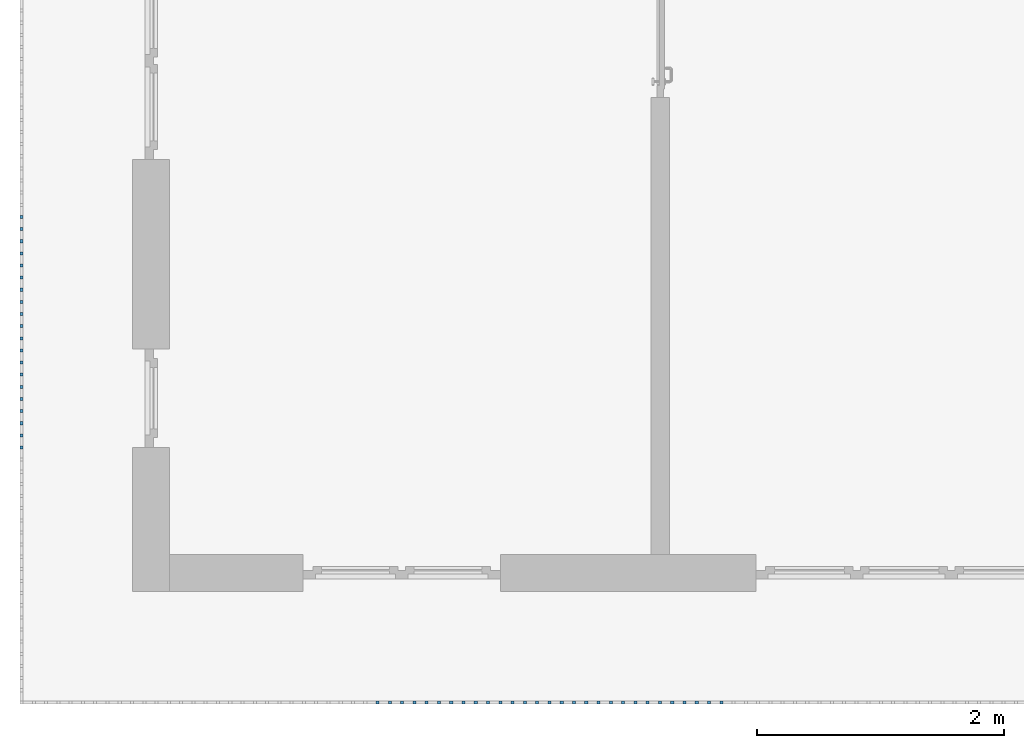
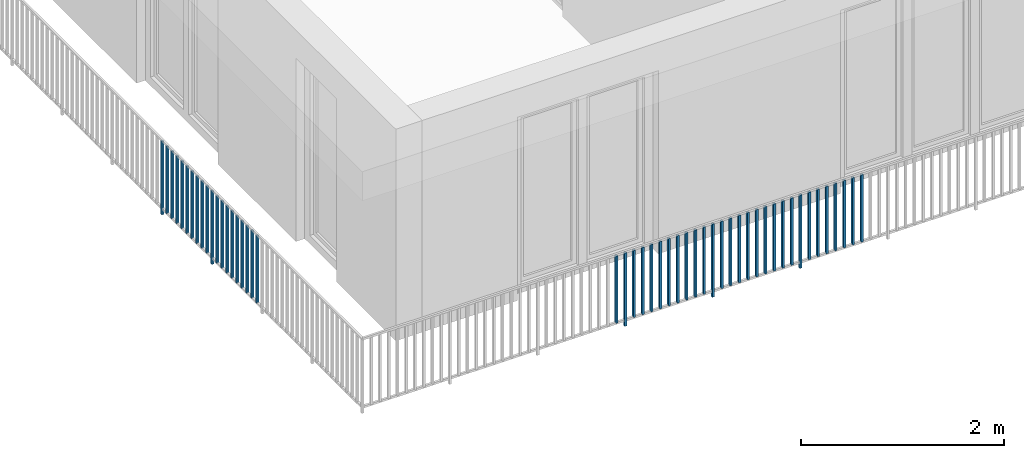
# One storey, part 33 of 54: 49 building element parts, 1 element without a shape of its own.
"""IFC4 building model written with IfcOpenShell, lengths in metres."""

from ifc_helpers import new_model, entity, si_unit, converted_unit, derived_unit, direction, frame, origin_with_axes, place, context, subcontext, project, spatial, polygons, material, type_object, element, aggregate, save


model = new_model("IFC4")

# Units and contexts
model_context = context("Model", 3, precision=1e-05, world=origin_with_axes(), true_north=direction((0.0, 1.0)))
body_context = subcontext(model_context, "Body", "Model", "MODEL_VIEW")
ifc_project = project(units=[si_unit("LENGTHUNIT", "METRE"), si_unit("AREAUNIT", "SQUARE_METRE"), si_unit("VOLUMEUNIT", "CUBIC_METRE"), converted_unit("PLANEANGLEUNIT", "DEGREE", entity("IfcPlaneAngleMeasure", 0.0174532925199), si_unit("PLANEANGLEUNIT", "RADIAN"), dimensions=[0, 0, 0, 0, 0, 0, 0]), converted_unit("TIMEUNIT", "Year", entity("IfcTimeMeasure", 31556926.0), si_unit("TIMEUNIT", "SECOND"), dimensions=[0, 0, 1, 0, 0, 0, 0]), si_unit("MASSUNIT", "GRAM", prefix="KILO"), si_unit("THERMODYNAMICTEMPERATUREUNIT", "DEGREE_CELSIUS"), si_unit("LUMINOUSINTENSITYUNIT", "LUMEN"), si_unit("ENERGYUNIT", "JOULE", prefix="MEGA"), derived_unit("THERMALCONDUCTANCEUNIT", [(si_unit("POWERUNIT", "WATT"), 1), (si_unit("LENGTHUNIT", "METRE"), -1), (si_unit("THERMODYNAMICTEMPERATUREUNIT", "KELVIN"), -1)]), derived_unit("SPECIFICHEATCAPACITYUNIT", [(si_unit("ENERGYUNIT", "JOULE"), 1), (si_unit("MASSUNIT", "GRAM", prefix="KILO"), -1), (si_unit("THERMODYNAMICTEMPERATUREUNIT", "KELVIN"), -1)]), derived_unit("MASSDENSITYUNIT", [(si_unit("MASSUNIT", "GRAM", prefix="KILO"), 1), (si_unit("VOLUMEUNIT", "CUBIC_METRE"), -1)])], contexts=[model_context])

# Site, building, storey, space
site_placement = place(None, origin_with_axes())
site = spatial("IfcSite", under=ifc_project, at=site_placement, CompositionType="ELEMENT")
building_placement = place(site_placement, origin_with_axes())
building = spatial("IfcBuilding", under=site, at=building_placement, CompositionType="ELEMENT")
storey_placement = place(building_placement, frame((0.0, 0.0, 9.18), z_axis=(0.0, 0.0, 1.0), x_axis=(1.0, 0.0, 0.0)))
storey = spatial("IfcBuildingStorey", under=building, at=storey_placement, Name="3. Geschoss", CompositionType="ELEMENT", Elevation=9.18)
space_placement = place(storey_placement, frame((10.2378006196, 9.82118769833, 0.0), z_axis=(0.0, 0.0, 1.0), x_axis=(-1.0, 0.0, 0.0)))
space = spatial("IfcSpace", under=storey, at=space_placement, CompositionType="ELEMENT", PredefinedType="EXTERNAL")

# Railing, building element parts
railing_type = type_object("IfcRailingType", PredefinedType="NOTDEFINED")
railing_placement = place(space_placement, frame((0.0, -7.06315681498e-08, 0.0), z_axis=(0.0, 0.0, 1.0), x_axis=(-1.0, 0.0, 0.0)))
railing = element("IfcRailing", 1, at=railing_placement, inside=space, type_object=railing_type, PredefinedType="NOTDEFINED")
ifc_material = material()
building_element_part_1_placement = place(railing_placement, origin_with_axes())
building_element_part_1 = element("IfcBuildingElementPart", 2, at=building_element_part_1_placement, material=ifc_material, PredefinedType="NOTDEFINED", context=body_context, shape_type="Tessellation", body=[
    polygons([(-22.8925, -16.7291666667, 0.0), (-22.8675, -16.7291666667, 0.0), (-22.8675, -16.7291666667, 0.88), (-22.8925, -16.7291666667, 0.88), (-22.8925, -16.7041666667, 0.0), (-22.8675, -16.7041666667, 0.0), (-22.8675, -16.7041666667, 0.88), (-22.8925, -16.7041666667, 0.88)], [[[1, 2, 3, 4]], [[1, 5, 6, 2]], [[2, 6, 7, 3]], [[4, 3, 7, 8]], [[5, 1, 4, 8]], [[6, 5, 8, 7]]], closed=True),
])
building_element_part_2_placement = place(railing_placement, origin_with_axes())
building_element_part_2 = element("IfcBuildingElementPart", 3, at=building_element_part_2_placement, material=ifc_material, PredefinedType="NOTDEFINED", context=body_context, shape_type="Tessellation", body=[
    polygons([(-22.8925, -16.8275, 0.07), (-22.8675, -16.8275, 0.07), (-22.8675, -16.8275, 0.8775), (-22.8925, -16.8275, 0.8775), (-22.8925, -16.8025, 0.07), (-22.8675, -16.8025, 0.07), (-22.8675, -16.8025, 0.8775), (-22.8925, -16.8025, 0.8775)], [[[1, 2, 3, 4]], [[1, 5, 6, 2]], [[2, 6, 7, 3]], [[4, 3, 7, 8]], [[5, 1, 4, 8]], [[6, 5, 8, 7]]], closed=True),
])
building_element_part_3_placement = place(railing_placement, origin_with_axes())
building_element_part_3 = element("IfcBuildingElementPart", 4, at=building_element_part_3_placement, material=ifc_material, PredefinedType="NOTDEFINED", context=body_context, shape_type="Tessellation", body=[
    polygons([(-22.8925, -16.9258333333, 0.07), (-22.8675, -16.9258333333, 0.07), (-22.8675, -16.9258333333, 0.8775), (-22.8925, -16.9258333333, 0.8775), (-22.8925, -16.9008333333, 0.07), (-22.8675, -16.9008333333, 0.07), (-22.8675, -16.9008333333, 0.8775), (-22.8925, -16.9008333333, 0.8775)], [[[1, 2, 3, 4]], [[1, 5, 6, 2]], [[2, 6, 7, 3]], [[4, 3, 7, 8]], [[5, 1, 4, 8]], [[6, 5, 8, 7]]], closed=True),
])
building_element_part_4_placement = place(railing_placement, origin_with_axes())
building_element_part_4 = element("IfcBuildingElementPart", 5, at=building_element_part_4_placement, material=ifc_material, PredefinedType="NOTDEFINED", context=body_context, shape_type="Tessellation", body=[
    polygons([(-22.8925, -17.0241666667, 0.07), (-22.8675, -17.0241666667, 0.07), (-22.8675, -17.0241666667, 0.8775), (-22.8925, -17.0241666667, 0.8775), (-22.8925, -16.9991666667, 0.07), (-22.8675, -16.9991666667, 0.07), (-22.8675, -16.9991666667, 0.8775), (-22.8925, -16.9991666667, 0.8775)], [[[1, 2, 3, 4]], [[1, 5, 6, 2]], [[2, 6, 7, 3]], [[4, 3, 7, 8]], [[5, 1, 4, 8]], [[6, 5, 8, 7]]], closed=True),
])
building_element_part_5_placement = place(railing_placement, origin_with_axes())
building_element_part_5 = element("IfcBuildingElementPart", 6, at=building_element_part_5_placement, material=ifc_material, PredefinedType="NOTDEFINED", context=body_context, shape_type="Tessellation", body=[
    polygons([(-22.8925, -17.1225, 0.07), (-22.8675, -17.1225, 0.07), (-22.8675, -17.1225, 0.8775), (-22.8925, -17.1225, 0.8775), (-22.8925, -17.0975, 0.07), (-22.8675, -17.0975, 0.07), (-22.8675, -17.0975, 0.8775), (-22.8925, -17.0975, 0.8775)], [[[1, 2, 3, 4]], [[1, 5, 6, 2]], [[2, 6, 7, 3]], [[4, 3, 7, 8]], [[5, 1, 4, 8]], [[6, 5, 8, 7]]], closed=True),
])
building_element_part_6_placement = place(railing_placement, origin_with_axes())
building_element_part_6 = element("IfcBuildingElementPart", 7, at=building_element_part_6_placement, material=ifc_material, PredefinedType="NOTDEFINED", context=body_context, shape_type="Tessellation", body=[
    polygons([(-22.8925, -17.2208333333, 0.07), (-22.8675, -17.2208333333, 0.07), (-22.8675, -17.2208333333, 0.8775), (-22.8925, -17.2208333333, 0.8775), (-22.8925, -17.1958333333, 0.07), (-22.8675, -17.1958333333, 0.07), (-22.8675, -17.1958333333, 0.8775), (-22.8925, -17.1958333333, 0.8775)], [[[1, 2, 3, 4]], [[1, 5, 6, 2]], [[2, 6, 7, 3]], [[4, 3, 7, 8]], [[5, 1, 4, 8]], [[6, 5, 8, 7]]], closed=True),
])
building_element_part_7_placement = place(railing_placement, origin_with_axes())
building_element_part_7 = element("IfcBuildingElementPart", 8, at=building_element_part_7_placement, material=ifc_material, PredefinedType="NOTDEFINED", context=body_context, shape_type="Tessellation", body=[
    polygons([(-22.8925, -17.3191666667, 0.07), (-22.8675, -17.3191666667, 0.07), (-22.8675, -17.3191666667, 0.8775), (-22.8925, -17.3191666667, 0.8775), (-22.8925, -17.2941666667, 0.07), (-22.8675, -17.2941666667, 0.07), (-22.8675, -17.2941666667, 0.8775), (-22.8925, -17.2941666667, 0.8775)], [[[1, 2, 3, 4]], [[1, 5, 6, 2]], [[2, 6, 7, 3]], [[4, 3, 7, 8]], [[5, 1, 4, 8]], [[6, 5, 8, 7]]], closed=True),
])
building_element_part_8_placement = place(railing_placement, origin_with_axes())
building_element_part_8 = element("IfcBuildingElementPart", 9, at=building_element_part_8_placement, material=ifc_material, PredefinedType="NOTDEFINED", context=body_context, shape_type="Tessellation", body=[
    polygons([(-22.8925, -17.4175, 0.07), (-22.8675, -17.4175, 0.07), (-22.8675, -17.4175, 0.8775), (-22.8925, -17.4175, 0.8775), (-22.8925, -17.3925, 0.07), (-22.8675, -17.3925, 0.07), (-22.8675, -17.3925, 0.8775), (-22.8925, -17.3925, 0.8775)], [[[1, 2, 3, 4]], [[1, 5, 6, 2]], [[2, 6, 7, 3]], [[4, 3, 7, 8]], [[5, 1, 4, 8]], [[6, 5, 8, 7]]], closed=True),
])
building_element_part_9_placement = place(railing_placement, origin_with_axes())
building_element_part_9 = element("IfcBuildingElementPart", 10, at=building_element_part_9_placement, material=ifc_material, PredefinedType="NOTDEFINED", context=body_context, shape_type="Tessellation", body=[
    polygons([(-22.8925, -17.5158333333, 0.07), (-22.8675, -17.5158333333, 0.07), (-22.8675, -17.5158333333, 0.8775), (-22.8925, -17.5158333333, 0.8775), (-22.8925, -17.4908333333, 0.07), (-22.8675, -17.4908333333, 0.07), (-22.8675, -17.4908333333, 0.8775), (-22.8925, -17.4908333333, 0.8775)], [[[1, 2, 3, 4]], [[1, 5, 6, 2]], [[2, 6, 7, 3]], [[4, 3, 7, 8]], [[5, 1, 4, 8]], [[6, 5, 8, 7]]], closed=True),
])
building_element_part_10_placement = place(railing_placement, origin_with_axes())
building_element_part_10 = element("IfcBuildingElementPart", 11, at=building_element_part_10_placement, material=ifc_material, PredefinedType="NOTDEFINED", context=body_context, shape_type="Tessellation", body=[
    polygons([(-22.8925, -17.6141666667, 0.07), (-22.8675, -17.6141666667, 0.07), (-22.8675, -17.6141666667, 0.8775), (-22.8925, -17.6141666667, 0.8775), (-22.8925, -17.5891666667, 0.07), (-22.8675, -17.5891666667, 0.07), (-22.8675, -17.5891666667, 0.8775), (-22.8925, -17.5891666667, 0.8775)], [[[1, 2, 3, 4]], [[1, 5, 6, 2]], [[2, 6, 7, 3]], [[4, 3, 7, 8]], [[5, 1, 4, 8]], [[6, 5, 8, 7]]], closed=True),
])
building_element_part_11_placement = place(railing_placement, origin_with_axes())
building_element_part_11 = element("IfcBuildingElementPart", 12, at=building_element_part_11_placement, material=ifc_material, PredefinedType="NOTDEFINED", context=body_context, shape_type="Tessellation", body=[
    polygons([(-22.8925, -17.7125, 0.0), (-22.8675, -17.7125, 0.0), (-22.8675, -17.7125, 0.88), (-22.8925, -17.7125, 0.88), (-22.8925, -17.6875, 0.0), (-22.8675, -17.6875, 0.0), (-22.8675, -17.6875, 0.88), (-22.8925, -17.6875, 0.88)], [[[1, 2, 3, 4]], [[1, 5, 6, 2]], [[2, 6, 7, 3]], [[4, 3, 7, 8]], [[5, 1, 4, 8]], [[6, 5, 8, 7]]], closed=True),
])
building_element_part_12_placement = place(railing_placement, origin_with_axes())
building_element_part_12 = element("IfcBuildingElementPart", 13, at=building_element_part_12_placement, material=ifc_material, PredefinedType="NOTDEFINED", context=body_context, shape_type="Tessellation", body=[
    polygons([(-22.8925, -17.8108333333, 0.07), (-22.8675, -17.8108333333, 0.07), (-22.8675, -17.8108333333, 0.8775), (-22.8925, -17.8108333333, 0.8775), (-22.8925, -17.7858333333, 0.07), (-22.8675, -17.7858333333, 0.07), (-22.8675, -17.7858333333, 0.8775), (-22.8925, -17.7858333333, 0.8775)], [[[1, 2, 3, 4]], [[1, 5, 6, 2]], [[2, 6, 7, 3]], [[4, 3, 7, 8]], [[5, 1, 4, 8]], [[6, 5, 8, 7]]], closed=True),
])
building_element_part_13_placement = place(railing_placement, origin_with_axes())
building_element_part_13 = element("IfcBuildingElementPart", 14, at=building_element_part_13_placement, material=ifc_material, PredefinedType="NOTDEFINED", context=body_context, shape_type="Tessellation", body=[
    polygons([(-22.8925, -17.9091666667, 0.07), (-22.8675, -17.9091666667, 0.07), (-22.8675, -17.9091666667, 0.8775), (-22.8925, -17.9091666667, 0.8775), (-22.8925, -17.8841666667, 0.07), (-22.8675, -17.8841666667, 0.07), (-22.8675, -17.8841666667, 0.8775), (-22.8925, -17.8841666667, 0.8775)], [[[1, 2, 3, 4]], [[1, 5, 6, 2]], [[2, 6, 7, 3]], [[4, 3, 7, 8]], [[5, 1, 4, 8]], [[6, 5, 8, 7]]], closed=True),
])
building_element_part_14_placement = place(railing_placement, origin_with_axes())
building_element_part_14 = element("IfcBuildingElementPart", 15, at=building_element_part_14_placement, material=ifc_material, PredefinedType="NOTDEFINED", context=body_context, shape_type="Tessellation", body=[
    polygons([(-22.8925, -18.0075, 0.07), (-22.8675, -18.0075, 0.07), (-22.8675, -18.0075, 0.8775), (-22.8925, -18.0075, 0.8775), (-22.8925, -17.9825, 0.07), (-22.8675, -17.9825, 0.07), (-22.8675, -17.9825, 0.8775), (-22.8925, -17.9825, 0.8775)], [[[1, 2, 3, 4]], [[1, 5, 6, 2]], [[2, 6, 7, 3]], [[4, 3, 7, 8]], [[5, 1, 4, 8]], [[6, 5, 8, 7]]], closed=True),
])
building_element_part_15_placement = place(railing_placement, origin_with_axes())
building_element_part_15 = element("IfcBuildingElementPart", 16, at=building_element_part_15_placement, material=ifc_material, PredefinedType="NOTDEFINED", context=body_context, shape_type="Tessellation", body=[
    polygons([(-22.8925, -18.1058333333, 0.07), (-22.8675, -18.1058333333, 0.07), (-22.8675, -18.1058333333, 0.8775), (-22.8925, -18.1058333333, 0.8775), (-22.8925, -18.0808333333, 0.07), (-22.8675, -18.0808333333, 0.07), (-22.8675, -18.0808333333, 0.8775), (-22.8925, -18.0808333333, 0.8775)], [[[1, 2, 3, 4]], [[1, 5, 6, 2]], [[2, 6, 7, 3]], [[4, 3, 7, 8]], [[5, 1, 4, 8]], [[6, 5, 8, 7]]], closed=True),
])
building_element_part_16_placement = place(railing_placement, origin_with_axes())
building_element_part_16 = element("IfcBuildingElementPart", 17, at=building_element_part_16_placement, material=ifc_material, PredefinedType="NOTDEFINED", context=body_context, shape_type="Tessellation", body=[
    polygons([(-22.8925, -18.2041666667, 0.07), (-22.8675, -18.2041666667, 0.07), (-22.8675, -18.2041666667, 0.8775), (-22.8925, -18.2041666667, 0.8775), (-22.8925, -18.1791666667, 0.07), (-22.8675, -18.1791666667, 0.07), (-22.8675, -18.1791666667, 0.8775), (-22.8925, -18.1791666667, 0.8775)], [[[1, 2, 3, 4]], [[1, 5, 6, 2]], [[2, 6, 7, 3]], [[4, 3, 7, 8]], [[5, 1, 4, 8]], [[6, 5, 8, 7]]], closed=True),
])
building_element_part_17_placement = place(railing_placement, origin_with_axes())
building_element_part_17 = element("IfcBuildingElementPart", 18, at=building_element_part_17_placement, material=ifc_material, PredefinedType="NOTDEFINED", context=body_context, shape_type="Tessellation", body=[
    polygons([(-22.8925, -18.3025, 0.07), (-22.8675, -18.3025, 0.07), (-22.8675, -18.3025, 0.8775), (-22.8925, -18.3025, 0.8775), (-22.8925, -18.2775, 0.07), (-22.8675, -18.2775, 0.07), (-22.8675, -18.2775, 0.8775), (-22.8925, -18.2775, 0.8775)], [[[1, 2, 3, 4]], [[1, 5, 6, 2]], [[2, 6, 7, 3]], [[4, 3, 7, 8]], [[5, 1, 4, 8]], [[6, 5, 8, 7]]], closed=True),
])
building_element_part_18_placement = place(railing_placement, origin_with_axes())
building_element_part_18 = element("IfcBuildingElementPart", 19, at=building_element_part_18_placement, material=ifc_material, PredefinedType="NOTDEFINED", context=body_context, shape_type="Tessellation", body=[
    polygons([(-22.8925, -18.4008333333, 0.07), (-22.8675, -18.4008333333, 0.07), (-22.8675, -18.4008333333, 0.8775), (-22.8925, -18.4008333333, 0.8775), (-22.8925, -18.3758333333, 0.07), (-22.8675, -18.3758333333, 0.07), (-22.8675, -18.3758333333, 0.8775), (-22.8925, -18.3758333333, 0.8775)], [[[1, 2, 3, 4]], [[1, 5, 6, 2]], [[2, 6, 7, 3]], [[4, 3, 7, 8]], [[5, 1, 4, 8]], [[6, 5, 8, 7]]], closed=True),
])
building_element_part_19_placement = place(railing_placement, origin_with_axes())
building_element_part_19 = element("IfcBuildingElementPart", 20, at=building_element_part_19_placement, material=ifc_material, PredefinedType="NOTDEFINED", context=body_context, shape_type="Tessellation", body=[
    polygons([(-22.8925, -18.4991666667, 0.07), (-22.8675, -18.4991666667, 0.07), (-22.8675, -18.4991666667, 0.8775), (-22.8925, -18.4991666667, 0.8775), (-22.8925, -18.4741666667, 0.07), (-22.8675, -18.4741666667, 0.07), (-22.8675, -18.4741666667, 0.8775), (-22.8925, -18.4741666667, 0.8775)], [[[1, 2, 3, 4]], [[1, 5, 6, 2]], [[2, 6, 7, 3]], [[4, 3, 7, 8]], [[5, 1, 4, 8]], [[6, 5, 8, 7]]], closed=True),
])
building_element_part_20_placement = place(railing_placement, origin_with_axes())
building_element_part_20 = element("IfcBuildingElementPart", 21, at=building_element_part_20_placement, material=ifc_material, PredefinedType="NOTDEFINED", context=body_context, shape_type="Tessellation", body=[
    polygons([(-22.8925, -18.5975, 0.07), (-22.8675, -18.5975, 0.07), (-22.8675, -18.5975, 0.8775), (-22.8925, -18.5975, 0.8775), (-22.8925, -18.5725, 0.07), (-22.8675, -18.5725, 0.07), (-22.8675, -18.5725, 0.8775), (-22.8925, -18.5725, 0.8775)], [[[1, 2, 3, 4]], [[1, 5, 6, 2]], [[2, 6, 7, 3]], [[4, 3, 7, 8]], [[5, 1, 4, 8]], [[6, 5, 8, 7]]], closed=True),
])
building_element_part_21_placement = place(railing_placement, origin_with_axes())
building_element_part_21 = element("IfcBuildingElementPart", 22, at=building_element_part_21_placement, material=ifc_material, PredefinedType="NOTDEFINED", context=body_context, shape_type="Tessellation", body=[
    polygons([(-19.9826304348, -20.6625, 0.07), (-19.9826304348, -20.6375, 0.07), (-19.9826304348, -20.6375, 0.8775), (-19.9826304348, -20.6625, 0.8775), (-20.0076304348, -20.6625, 0.07), (-20.0076304348, -20.6375, 0.07), (-20.0076304348, -20.6375, 0.8775), (-20.0076304348, -20.6625, 0.8775)], [[[1, 2, 3, 4]], [[1, 5, 6, 2]], [[2, 6, 7, 3]], [[4, 3, 7, 8]], [[5, 1, 4, 8]], [[6, 5, 8, 7]]], closed=True),
])
building_element_part_22_placement = place(railing_placement, origin_with_axes())
building_element_part_22 = element("IfcBuildingElementPart", 23, at=building_element_part_22_placement, material=ifc_material, PredefinedType="NOTDEFINED", context=body_context, shape_type="Tessellation", body=[
    polygons([(-19.8831521739, -20.6625, 0.0), (-19.8831521739, -20.6375, 0.0), (-19.8831521739, -20.6375, 0.88), (-19.8831521739, -20.6625, 0.88), (-19.9081521739, -20.6625, 0.0), (-19.9081521739, -20.6375, 0.0), (-19.9081521739, -20.6375, 0.88), (-19.9081521739, -20.6625, 0.88)], [[[1, 2, 3, 4]], [[1, 5, 6, 2]], [[2, 6, 7, 3]], [[4, 3, 7, 8]], [[5, 1, 4, 8]], [[6, 5, 8, 7]]], closed=True),
])
building_element_part_23_placement = place(railing_placement, origin_with_axes())
building_element_part_23 = element("IfcBuildingElementPart", 24, at=building_element_part_23_placement, material=ifc_material, PredefinedType="NOTDEFINED", context=body_context, shape_type="Tessellation", body=[
    polygons([(-19.783673913, -20.6625, 0.07), (-19.783673913, -20.6375, 0.07), (-19.783673913, -20.6375, 0.8775), (-19.783673913, -20.6625, 0.8775), (-19.808673913, -20.6625, 0.07), (-19.808673913, -20.6375, 0.07), (-19.808673913, -20.6375, 0.8775), (-19.808673913, -20.6625, 0.8775)], [[[1, 2, 3, 4]], [[1, 5, 6, 2]], [[2, 6, 7, 3]], [[4, 3, 7, 8]], [[5, 1, 4, 8]], [[6, 5, 8, 7]]], closed=True),
])
building_element_part_24_placement = place(railing_placement, origin_with_axes())
building_element_part_24 = element("IfcBuildingElementPart", 25, at=building_element_part_24_placement, material=ifc_material, PredefinedType="NOTDEFINED", context=body_context, shape_type="Tessellation", body=[
    polygons([(-19.6841956522, -20.6625, 0.07), (-19.6841956522, -20.6375, 0.07), (-19.6841956522, -20.6375, 0.8775), (-19.6841956522, -20.6625, 0.8775), (-19.7091956522, -20.6625, 0.07), (-19.7091956522, -20.6375, 0.07), (-19.7091956522, -20.6375, 0.8775), (-19.7091956522, -20.6625, 0.8775)], [[[1, 2, 3, 4]], [[1, 5, 6, 2]], [[2, 6, 7, 3]], [[4, 3, 7, 8]], [[5, 1, 4, 8]], [[6, 5, 8, 7]]], closed=True),
])
building_element_part_25_placement = place(railing_placement, origin_with_axes())
building_element_part_25 = element("IfcBuildingElementPart", 26, at=building_element_part_25_placement, material=ifc_material, PredefinedType="NOTDEFINED", context=body_context, shape_type="Tessellation", body=[
    polygons([(-19.5847173913, -20.6625, 0.07), (-19.5847173913, -20.6375, 0.07), (-19.5847173913, -20.6375, 0.8775), (-19.5847173913, -20.6625, 0.8775), (-19.6097173913, -20.6625, 0.07), (-19.6097173913, -20.6375, 0.07), (-19.6097173913, -20.6375, 0.8775), (-19.6097173913, -20.6625, 0.8775)], [[[1, 2, 3, 4]], [[1, 5, 6, 2]], [[2, 6, 7, 3]], [[4, 3, 7, 8]], [[5, 1, 4, 8]], [[6, 5, 8, 7]]], closed=True),
])
building_element_part_26_placement = place(railing_placement, origin_with_axes())
building_element_part_26 = element("IfcBuildingElementPart", 27, at=building_element_part_26_placement, material=ifc_material, PredefinedType="NOTDEFINED", context=body_context, shape_type="Tessellation", body=[
    polygons([(-19.4852391304, -20.6625, 0.07), (-19.4852391304, -20.6375, 0.07), (-19.4852391304, -20.6375, 0.8775), (-19.4852391304, -20.6625, 0.8775), (-19.5102391304, -20.6625, 0.07), (-19.5102391304, -20.6375, 0.07), (-19.5102391304, -20.6375, 0.8775), (-19.5102391304, -20.6625, 0.8775)], [[[1, 2, 3, 4]], [[1, 5, 6, 2]], [[2, 6, 7, 3]], [[4, 3, 7, 8]], [[5, 1, 4, 8]], [[6, 5, 8, 7]]], closed=True),
])
building_element_part_27_placement = place(railing_placement, origin_with_axes())
building_element_part_27 = element("IfcBuildingElementPart", 28, at=building_element_part_27_placement, material=ifc_material, PredefinedType="NOTDEFINED", context=body_context, shape_type="Tessellation", body=[
    polygons([(-19.3857608696, -20.6625, 0.07), (-19.3857608696, -20.6375, 0.07), (-19.3857608696, -20.6375, 0.8775), (-19.3857608696, -20.6625, 0.8775), (-19.4107608696, -20.6625, 0.07), (-19.4107608696, -20.6375, 0.07), (-19.4107608696, -20.6375, 0.8775), (-19.4107608696, -20.6625, 0.8775)], [[[1, 2, 3, 4]], [[1, 5, 6, 2]], [[2, 6, 7, 3]], [[4, 3, 7, 8]], [[5, 1, 4, 8]], [[6, 5, 8, 7]]], closed=True),
])
building_element_part_28_placement = place(railing_placement, origin_with_axes())
building_element_part_28 = element("IfcBuildingElementPart", 29, at=building_element_part_28_placement, material=ifc_material, PredefinedType="NOTDEFINED", context=body_context, shape_type="Tessellation", body=[
    polygons([(-19.2862826087, -20.6625, 0.07), (-19.2862826087, -20.6375, 0.07), (-19.2862826087, -20.6375, 0.8775), (-19.2862826087, -20.6625, 0.8775), (-19.3112826087, -20.6625, 0.07), (-19.3112826087, -20.6375, 0.07), (-19.3112826087, -20.6375, 0.8775), (-19.3112826087, -20.6625, 0.8775)], [[[1, 2, 3, 4]], [[1, 5, 6, 2]], [[2, 6, 7, 3]], [[4, 3, 7, 8]], [[5, 1, 4, 8]], [[6, 5, 8, 7]]], closed=True),
])
building_element_part_29_placement = place(railing_placement, origin_with_axes())
building_element_part_29 = element("IfcBuildingElementPart", 30, at=building_element_part_29_placement, material=ifc_material, PredefinedType="NOTDEFINED", context=body_context, shape_type="Tessellation", body=[
    polygons([(-19.1868043478, -20.6625, 0.07), (-19.1868043478, -20.6375, 0.07), (-19.1868043478, -20.6375, 0.8775), (-19.1868043478, -20.6625, 0.8775), (-19.2118043478, -20.6625, 0.07), (-19.2118043478, -20.6375, 0.07), (-19.2118043478, -20.6375, 0.8775), (-19.2118043478, -20.6625, 0.8775)], [[[1, 2, 3, 4]], [[1, 5, 6, 2]], [[2, 6, 7, 3]], [[4, 3, 7, 8]], [[5, 1, 4, 8]], [[6, 5, 8, 7]]], closed=True),
])
building_element_part_30_placement = place(railing_placement, origin_with_axes())
building_element_part_30 = element("IfcBuildingElementPart", 31, at=building_element_part_30_placement, material=ifc_material, PredefinedType="NOTDEFINED", context=body_context, shape_type="Tessellation", body=[
    polygons([(-19.087326087, -20.6625, 0.07), (-19.087326087, -20.6375, 0.07), (-19.087326087, -20.6375, 0.8775), (-19.087326087, -20.6625, 0.8775), (-19.112326087, -20.6625, 0.07), (-19.112326087, -20.6375, 0.07), (-19.112326087, -20.6375, 0.8775), (-19.112326087, -20.6625, 0.8775)], [[[1, 2, 3, 4]], [[1, 5, 6, 2]], [[2, 6, 7, 3]], [[4, 3, 7, 8]], [[5, 1, 4, 8]], [[6, 5, 8, 7]]], closed=True),
])
building_element_part_31_placement = place(railing_placement, origin_with_axes())
building_element_part_31 = element("IfcBuildingElementPart", 32, at=building_element_part_31_placement, material=ifc_material, PredefinedType="NOTDEFINED", context=body_context, shape_type="Tessellation", body=[
    polygons([(-18.9878478261, -20.6625, 0.07), (-18.9878478261, -20.6375, 0.07), (-18.9878478261, -20.6375, 0.8775), (-18.9878478261, -20.6625, 0.8775), (-19.0128478261, -20.6625, 0.07), (-19.0128478261, -20.6375, 0.07), (-19.0128478261, -20.6375, 0.8775), (-19.0128478261, -20.6625, 0.8775)], [[[1, 2, 3, 4]], [[1, 5, 6, 2]], [[2, 6, 7, 3]], [[4, 3, 7, 8]], [[5, 1, 4, 8]], [[6, 5, 8, 7]]], closed=True),
])
building_element_part_32_placement = place(railing_placement, origin_with_axes())
building_element_part_32 = element("IfcBuildingElementPart", 33, at=building_element_part_32_placement, material=ifc_material, PredefinedType="NOTDEFINED", context=body_context, shape_type="Tessellation", body=[
    polygons([(-18.8883695652, -20.6625, 0.0), (-18.8883695652, -20.6375, 0.0), (-18.8883695652, -20.6375, 0.88), (-18.8883695652, -20.6625, 0.88), (-18.9133695652, -20.6625, 0.0), (-18.9133695652, -20.6375, 0.0), (-18.9133695652, -20.6375, 0.88), (-18.9133695652, -20.6625, 0.88)], [[[1, 2, 3, 4]], [[1, 5, 6, 2]], [[2, 6, 7, 3]], [[4, 3, 7, 8]], [[5, 1, 4, 8]], [[6, 5, 8, 7]]], closed=True),
])
building_element_part_33_placement = place(railing_placement, origin_with_axes())
building_element_part_33 = element("IfcBuildingElementPart", 34, at=building_element_part_33_placement, material=ifc_material, PredefinedType="NOTDEFINED", context=body_context, shape_type="Tessellation", body=[
    polygons([(-18.7888913043, -20.6625, 0.07), (-18.7888913043, -20.6375, 0.07), (-18.7888913043, -20.6375, 0.8775), (-18.7888913043, -20.6625, 0.8775), (-18.8138913043, -20.6625, 0.07), (-18.8138913043, -20.6375, 0.07), (-18.8138913043, -20.6375, 0.8775), (-18.8138913043, -20.6625, 0.8775)], [[[1, 2, 3, 4]], [[1, 5, 6, 2]], [[2, 6, 7, 3]], [[4, 3, 7, 8]], [[5, 1, 4, 8]], [[6, 5, 8, 7]]], closed=True),
])
building_element_part_34_placement = place(railing_placement, origin_with_axes())
building_element_part_34 = element("IfcBuildingElementPart", 35, at=building_element_part_34_placement, material=ifc_material, PredefinedType="NOTDEFINED", context=body_context, shape_type="Tessellation", body=[
    polygons([(-18.6894130435, -20.6625, 0.07), (-18.6894130435, -20.6375, 0.07), (-18.6894130435, -20.6375, 0.8775), (-18.6894130435, -20.6625, 0.8775), (-18.7144130435, -20.6625, 0.07), (-18.7144130435, -20.6375, 0.07), (-18.7144130435, -20.6375, 0.8775), (-18.7144130435, -20.6625, 0.8775)], [[[1, 2, 3, 4]], [[1, 5, 6, 2]], [[2, 6, 7, 3]], [[4, 3, 7, 8]], [[5, 1, 4, 8]], [[6, 5, 8, 7]]], closed=True),
])
building_element_part_35_placement = place(railing_placement, origin_with_axes())
building_element_part_35 = element("IfcBuildingElementPart", 36, at=building_element_part_35_placement, material=ifc_material, PredefinedType="NOTDEFINED", context=body_context, shape_type="Tessellation", body=[
    polygons([(-18.5899347826, -20.6625, 0.07), (-18.5899347826, -20.6375, 0.07), (-18.5899347826, -20.6375, 0.8775), (-18.5899347826, -20.6625, 0.8775), (-18.6149347826, -20.6625, 0.07), (-18.6149347826, -20.6375, 0.07), (-18.6149347826, -20.6375, 0.8775), (-18.6149347826, -20.6625, 0.8775)], [[[1, 2, 3, 4]], [[1, 5, 6, 2]], [[2, 6, 7, 3]], [[4, 3, 7, 8]], [[5, 1, 4, 8]], [[6, 5, 8, 7]]], closed=True),
])
building_element_part_36_placement = place(railing_placement, origin_with_axes())
building_element_part_36 = element("IfcBuildingElementPart", 37, at=building_element_part_36_placement, material=ifc_material, PredefinedType="NOTDEFINED", context=body_context, shape_type="Tessellation", body=[
    polygons([(-18.4904565217, -20.6625, 0.07), (-18.4904565217, -20.6375, 0.07), (-18.4904565217, -20.6375, 0.8775), (-18.4904565217, -20.6625, 0.8775), (-18.5154565217, -20.6625, 0.07), (-18.5154565217, -20.6375, 0.07), (-18.5154565217, -20.6375, 0.8775), (-18.5154565217, -20.6625, 0.8775)], [[[1, 2, 3, 4]], [[1, 5, 6, 2]], [[2, 6, 7, 3]], [[4, 3, 7, 8]], [[5, 1, 4, 8]], [[6, 5, 8, 7]]], closed=True),
])
building_element_part_37_placement = place(railing_placement, origin_with_axes())
building_element_part_37 = element("IfcBuildingElementPart", 38, at=building_element_part_37_placement, material=ifc_material, PredefinedType="NOTDEFINED", context=body_context, shape_type="Tessellation", body=[
    polygons([(-18.3909782609, -20.6625, 0.07), (-18.3909782609, -20.6375, 0.07), (-18.3909782609, -20.6375, 0.8775), (-18.3909782609, -20.6625, 0.8775), (-18.4159782609, -20.6625, 0.07), (-18.4159782609, -20.6375, 0.07), (-18.4159782609, -20.6375, 0.8775), (-18.4159782609, -20.6625, 0.8775)], [[[1, 2, 3, 4]], [[1, 5, 6, 2]], [[2, 6, 7, 3]], [[4, 3, 7, 8]], [[5, 1, 4, 8]], [[6, 5, 8, 7]]], closed=True),
])
building_element_part_38_placement = place(railing_placement, origin_with_axes())
building_element_part_38 = element("IfcBuildingElementPart", 39, at=building_element_part_38_placement, material=ifc_material, PredefinedType="NOTDEFINED", context=body_context, shape_type="Tessellation", body=[
    polygons([(-18.2915, -20.6625, 0.07), (-18.2915, -20.6375, 0.07), (-18.2915, -20.6375, 0.8775), (-18.2915, -20.6625, 0.8775), (-18.3165, -20.6625, 0.07), (-18.3165, -20.6375, 0.07), (-18.3165, -20.6375, 0.8775), (-18.3165, -20.6625, 0.8775)], [[[1, 2, 3, 4]], [[1, 5, 6, 2]], [[2, 6, 7, 3]], [[4, 3, 7, 8]], [[5, 1, 4, 8]], [[6, 5, 8, 7]]], closed=True),
])
building_element_part_39_placement = place(railing_placement, origin_with_axes())
building_element_part_39 = element("IfcBuildingElementPart", 40, at=building_element_part_39_placement, material=ifc_material, PredefinedType="NOTDEFINED", context=body_context, shape_type="Tessellation", body=[
    polygons([(-18.1920217391, -20.6625, 0.07), (-18.1920217391, -20.6375, 0.07), (-18.1920217391, -20.6375, 0.8775), (-18.1920217391, -20.6625, 0.8775), (-18.2170217391, -20.6625, 0.07), (-18.2170217391, -20.6375, 0.07), (-18.2170217391, -20.6375, 0.8775), (-18.2170217391, -20.6625, 0.8775)], [[[1, 2, 3, 4]], [[1, 5, 6, 2]], [[2, 6, 7, 3]], [[4, 3, 7, 8]], [[5, 1, 4, 8]], [[6, 5, 8, 7]]], closed=True),
])
building_element_part_40_placement = place(railing_placement, origin_with_axes())
building_element_part_40 = element("IfcBuildingElementPart", 41, at=building_element_part_40_placement, material=ifc_material, PredefinedType="NOTDEFINED", context=body_context, shape_type="Tessellation", body=[
    polygons([(-18.0925434783, -20.6625, 0.07), (-18.0925434783, -20.6375, 0.07), (-18.0925434783, -20.6375, 0.8775), (-18.0925434783, -20.6625, 0.8775), (-18.1175434783, -20.6625, 0.07), (-18.1175434783, -20.6375, 0.07), (-18.1175434783, -20.6375, 0.8775), (-18.1175434783, -20.6625, 0.8775)], [[[1, 2, 3, 4]], [[1, 5, 6, 2]], [[2, 6, 7, 3]], [[4, 3, 7, 8]], [[5, 1, 4, 8]], [[6, 5, 8, 7]]], closed=True),
])
building_element_part_41_placement = place(railing_placement, origin_with_axes())
building_element_part_41 = element("IfcBuildingElementPart", 42, at=building_element_part_41_placement, material=ifc_material, PredefinedType="NOTDEFINED", context=body_context, shape_type="Tessellation", body=[
    polygons([(-17.9930652174, -20.6625, 0.07), (-17.9930652174, -20.6375, 0.07), (-17.9930652174, -20.6375, 0.8775), (-17.9930652174, -20.6625, 0.8775), (-18.0180652174, -20.6625, 0.07), (-18.0180652174, -20.6375, 0.07), (-18.0180652174, -20.6375, 0.8775), (-18.0180652174, -20.6625, 0.8775)], [[[1, 2, 3, 4]], [[1, 5, 6, 2]], [[2, 6, 7, 3]], [[4, 3, 7, 8]], [[5, 1, 4, 8]], [[6, 5, 8, 7]]], closed=True),
])
building_element_part_42_placement = place(railing_placement, origin_with_axes())
building_element_part_42 = element("IfcBuildingElementPart", 43, at=building_element_part_42_placement, material=ifc_material, PredefinedType="NOTDEFINED", context=body_context, shape_type="Tessellation", body=[
    polygons([(-17.8935869565, -20.6625, 0.0), (-17.8935869565, -20.6375, 0.0), (-17.8935869565, -20.6375, 0.88), (-17.8935869565, -20.6625, 0.88), (-17.9185869565, -20.6625, 0.0), (-17.9185869565, -20.6375, 0.0), (-17.9185869565, -20.6375, 0.88), (-17.9185869565, -20.6625, 0.88)], [[[1, 2, 3, 4]], [[1, 5, 6, 2]], [[2, 6, 7, 3]], [[4, 3, 7, 8]], [[5, 1, 4, 8]], [[6, 5, 8, 7]]], closed=True),
])
building_element_part_43_placement = place(railing_placement, origin_with_axes())
building_element_part_43 = element("IfcBuildingElementPart", 44, at=building_element_part_43_placement, material=ifc_material, PredefinedType="NOTDEFINED", context=body_context, shape_type="Tessellation", body=[
    polygons([(-17.7941086957, -20.6625, 0.07), (-17.7941086957, -20.6375, 0.07), (-17.7941086957, -20.6375, 0.8775), (-17.7941086957, -20.6625, 0.8775), (-17.8191086957, -20.6625, 0.07), (-17.8191086957, -20.6375, 0.07), (-17.8191086957, -20.6375, 0.8775), (-17.8191086957, -20.6625, 0.8775)], [[[1, 2, 3, 4]], [[1, 5, 6, 2]], [[2, 6, 7, 3]], [[4, 3, 7, 8]], [[5, 1, 4, 8]], [[6, 5, 8, 7]]], closed=True),
])
building_element_part_44_placement = place(railing_placement, origin_with_axes())
building_element_part_44 = element("IfcBuildingElementPart", 45, at=building_element_part_44_placement, material=ifc_material, PredefinedType="NOTDEFINED", context=body_context, shape_type="Tessellation", body=[
    polygons([(-17.6946304348, -20.6625, 0.07), (-17.6946304348, -20.6375, 0.07), (-17.6946304348, -20.6375, 0.8775), (-17.6946304348, -20.6625, 0.8775), (-17.7196304348, -20.6625, 0.07), (-17.7196304348, -20.6375, 0.07), (-17.7196304348, -20.6375, 0.8775), (-17.7196304348, -20.6625, 0.8775)], [[[1, 2, 3, 4]], [[1, 5, 6, 2]], [[2, 6, 7, 3]], [[4, 3, 7, 8]], [[5, 1, 4, 8]], [[6, 5, 8, 7]]], closed=True),
])
building_element_part_45_placement = place(railing_placement, origin_with_axes())
building_element_part_45 = element("IfcBuildingElementPart", 46, at=building_element_part_45_placement, material=ifc_material, PredefinedType="NOTDEFINED", context=body_context, shape_type="Tessellation", body=[
    polygons([(-17.5951521739, -20.6625, 0.07), (-17.5951521739, -20.6375, 0.07), (-17.5951521739, -20.6375, 0.8775), (-17.5951521739, -20.6625, 0.8775), (-17.6201521739, -20.6625, 0.07), (-17.6201521739, -20.6375, 0.07), (-17.6201521739, -20.6375, 0.8775), (-17.6201521739, -20.6625, 0.8775)], [[[1, 2, 3, 4]], [[1, 5, 6, 2]], [[2, 6, 7, 3]], [[4, 3, 7, 8]], [[5, 1, 4, 8]], [[6, 5, 8, 7]]], closed=True),
])
building_element_part_46_placement = place(railing_placement, origin_with_axes())
building_element_part_46 = element("IfcBuildingElementPart", 47, at=building_element_part_46_placement, material=ifc_material, PredefinedType="NOTDEFINED", context=body_context, shape_type="Tessellation", body=[
    polygons([(-17.495673913, -20.6625, 0.07), (-17.495673913, -20.6375, 0.07), (-17.495673913, -20.6375, 0.8775), (-17.495673913, -20.6625, 0.8775), (-17.520673913, -20.6625, 0.07), (-17.520673913, -20.6375, 0.07), (-17.520673913, -20.6375, 0.8775), (-17.520673913, -20.6625, 0.8775)], [[[1, 2, 3, 4]], [[1, 5, 6, 2]], [[2, 6, 7, 3]], [[4, 3, 7, 8]], [[5, 1, 4, 8]], [[6, 5, 8, 7]]], closed=True),
])
building_element_part_47_placement = place(railing_placement, origin_with_axes())
building_element_part_47 = element("IfcBuildingElementPart", 48, at=building_element_part_47_placement, material=ifc_material, PredefinedType="NOTDEFINED", context=body_context, shape_type="Tessellation", body=[
    polygons([(-17.3961956522, -20.6625, 0.07), (-17.3961956522, -20.6375, 0.07), (-17.3961956522, -20.6375, 0.8775), (-17.3961956522, -20.6625, 0.8775), (-17.4211956522, -20.6625, 0.07), (-17.4211956522, -20.6375, 0.07), (-17.4211956522, -20.6375, 0.8775), (-17.4211956522, -20.6625, 0.8775)], [[[1, 2, 3, 4]], [[1, 5, 6, 2]], [[2, 6, 7, 3]], [[4, 3, 7, 8]], [[5, 1, 4, 8]], [[6, 5, 8, 7]]], closed=True),
])
building_element_part_48_placement = place(railing_placement, origin_with_axes())
building_element_part_48 = element("IfcBuildingElementPart", 49, at=building_element_part_48_placement, material=ifc_material, PredefinedType="NOTDEFINED", context=body_context, shape_type="Tessellation", body=[
    polygons([(-17.2967173913, -20.6625, 0.07), (-17.2967173913, -20.6375, 0.07), (-17.2967173913, -20.6375, 0.8775), (-17.2967173913, -20.6625, 0.8775), (-17.3217173913, -20.6625, 0.07), (-17.3217173913, -20.6375, 0.07), (-17.3217173913, -20.6375, 0.8775), (-17.3217173913, -20.6625, 0.8775)], [[[1, 2, 3, 4]], [[1, 5, 6, 2]], [[2, 6, 7, 3]], [[4, 3, 7, 8]], [[5, 1, 4, 8]], [[6, 5, 8, 7]]], closed=True),
])
building_element_part_49_placement = place(railing_placement, origin_with_axes())
building_element_part_49 = element("IfcBuildingElementPart", 50, at=building_element_part_49_placement, material=ifc_material, PredefinedType="NOTDEFINED", context=body_context, shape_type="Tessellation", body=[
    polygons([(-17.1972391304, -20.6625, 0.07), (-17.1972391304, -20.6375, 0.07), (-17.1972391304, -20.6375, 0.8775), (-17.1972391304, -20.6625, 0.8775), (-17.2222391304, -20.6625, 0.07), (-17.2222391304, -20.6375, 0.07), (-17.2222391304, -20.6375, 0.8775), (-17.2222391304, -20.6625, 0.8775)], [[[1, 2, 3, 4]], [[1, 5, 6, 2]], [[2, 6, 7, 3]], [[4, 3, 7, 8]], [[5, 1, 4, 8]], [[6, 5, 8, 7]]], closed=True),
])
aggregate(railing, [building_element_part_1, building_element_part_2, building_element_part_3, building_element_part_4, building_element_part_5, building_element_part_6, building_element_part_7, building_element_part_8, building_element_part_9, building_element_part_10, building_element_part_11, building_element_part_12, building_element_part_13, building_element_part_14, building_element_part_15, building_element_part_16, building_element_part_17, building_element_part_18, building_element_part_19, building_element_part_20, building_element_part_21, building_element_part_22, building_element_part_23, building_element_part_24, building_element_part_25, building_element_part_26, building_element_part_27, building_element_part_28, building_element_part_29, building_element_part_30, building_element_part_31, building_element_part_32, building_element_part_33, building_element_part_34, building_element_part_35, building_element_part_36, building_element_part_37, building_element_part_38, building_element_part_39, building_element_part_40, building_element_part_41, building_element_part_42, building_element_part_43, building_element_part_44, building_element_part_45, building_element_part_46, building_element_part_47, building_element_part_48, building_element_part_49])

save(model, "model.ifc")
